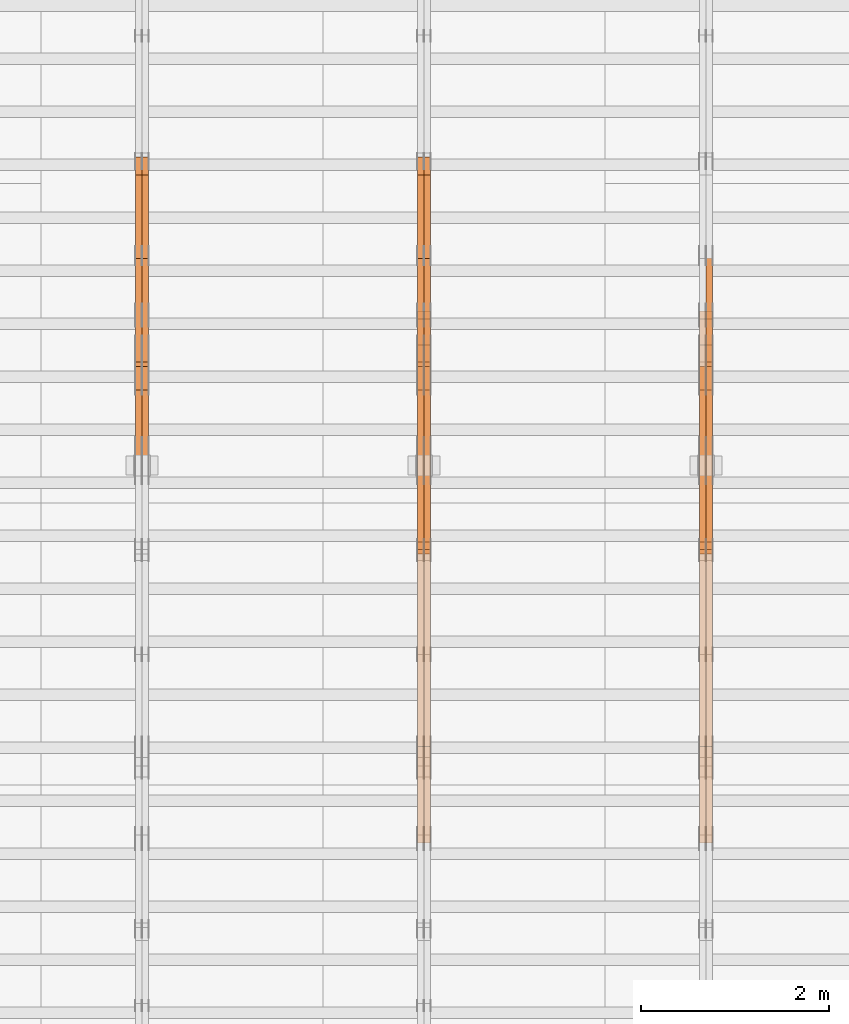
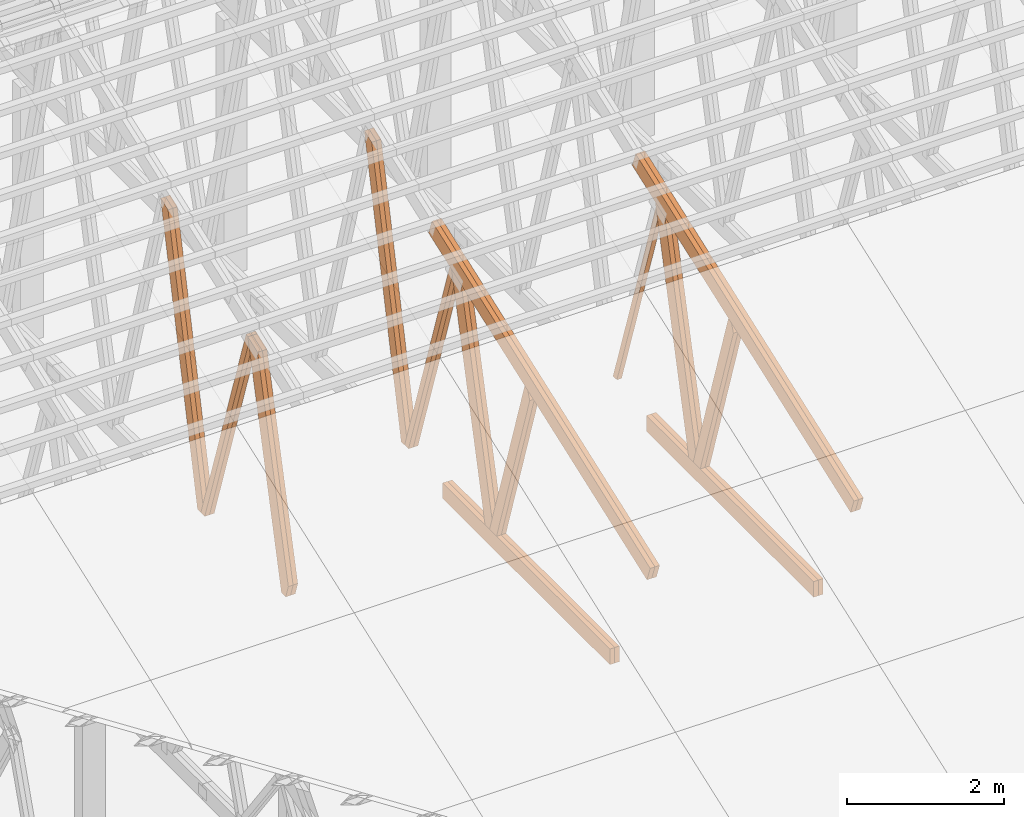
# One storey, part 25 of 189: 27 proxies.
"""IFC2X3 building model written with IfcOpenShell, lengths in millimetres."""

from ifc_helpers import new_model, entity, si_unit, converted_unit, derived_unit, direction, frame, origin, origin_2d_with_axis, place, context, subcontext, project, spatial, polyline, rectangle, outline, extrude, source, transform, mapped, material, type_object, type_shapes, element, save


model = new_model("IFC2X3")

# Units and contexts
model_context = context("Model", 3, precision=0.01, world=origin(), true_north=direction((6.12303176911189e-17, 1.0)))
body_context = subcontext(model_context, "Body", "Model", "MODEL_VIEW")
ifc_project = project(units=[si_unit("LENGTHUNIT", "METRE", prefix="MILLI"), si_unit("AREAUNIT", "SQUARE_METRE"), si_unit("VOLUMEUNIT", "CUBIC_METRE"), converted_unit("PLANEANGLEUNIT", "DEGREE", entity("IfcRatioMeasure", 0.0174532925199433), si_unit("PLANEANGLEUNIT", "RADIAN"), dimensions=[0, 0, 0, 0, 0, 0, 0]), si_unit("MASSUNIT", "GRAM", prefix="KILO"), derived_unit("MASSDENSITYUNIT", [(si_unit("MASSUNIT", "GRAM", prefix="KILO"), 1), (si_unit("LENGTHUNIT", "METRE"), -3)]), si_unit("TIMEUNIT", "SECOND"), si_unit("FREQUENCYUNIT", "HERTZ"), si_unit("THERMODYNAMICTEMPERATUREUNIT", "DEGREE_CELSIUS"), derived_unit("THERMALTRANSMITTANCEUNIT", [(si_unit("MASSUNIT", "GRAM", prefix="KILO"), 1), (si_unit("THERMODYNAMICTEMPERATUREUNIT", "KELVIN"), -1), (si_unit("TIMEUNIT", "SECOND"), -3)]), derived_unit("VOLUMETRICFLOWRATEUNIT", [(si_unit("LENGTHUNIT", "METRE"), 3), (si_unit("TIMEUNIT", "SECOND"), -1)]), si_unit("ELECTRICCURRENTUNIT", "AMPERE"), si_unit("ELECTRICVOLTAGEUNIT", "VOLT"), si_unit("POWERUNIT", "WATT"), si_unit("FORCEUNIT", "NEWTON"), si_unit("ILLUMINANCEUNIT", "LUX"), si_unit("LUMINOUSFLUXUNIT", "LUMEN"), si_unit("LUMINOUSINTENSITYUNIT", "CANDELA"), derived_unit("USERDEFINED", [(si_unit("MASSUNIT", "GRAM", prefix="KILO"), -1), (si_unit("LENGTHUNIT", "METRE"), -2), (si_unit("TIMEUNIT", "SECOND"), 3), (si_unit("LUMINOUSFLUXUNIT", "LUMEN"), 1)]), derived_unit("LINEARVELOCITYUNIT", [(si_unit("LENGTHUNIT", "METRE"), 1), (si_unit("TIMEUNIT", "SECOND"), -1)]), si_unit("PRESSUREUNIT", "PASCAL"), derived_unit("USERDEFINED", [(si_unit("LENGTHUNIT", "METRE"), -2), (si_unit("MASSUNIT", "GRAM", prefix="KILO"), 1), (si_unit("TIMEUNIT", "SECOND"), -2)])], contexts=[model_context])

# Site, building, storey
site_placement = place(None, origin())
site = spatial("IfcSite", under=ifc_project, at=site_placement, CompositionType="ELEMENT")
building_placement = place(site_placement, origin())
building = spatial("IfcBuilding", under=site, at=building_placement, CompositionType="ELEMENT")
storey_placement = place(building_placement, origin())
storey = spatial("IfcBuildingStorey", under=building, at=storey_placement, Name="Default", CompositionType="ELEMENT", Elevation=0.0)

# Proxies
ifc_material_1 = material(Name="IfcSurfaceStyle #115212")
building_element_proxy_type_1 = type_object("IfcBuildingElementProxyType", Name="T1-W7 115210", PredefinedType="NOTDEFINED", material=ifc_material_1)
shared_shape_1 = source(origin(), body_context, "Body", "SweptSolid", [
    extrude(outline(polyline([(-2158.15323194511, -47.5001976605119), (1398.58481981178, -47.5001976605119), (1473.93376219819, -0.000131511554346808), (1475.30069254941, 47.5002634162891), (-2189.66604261427, 47.5002634162891), (-2158.15323194511, -47.5001976605119)])), frame((1475.30069254941, 47.5002634162891, 0.0), z_axis=(0.0, 0.0, 1.0), x_axis=(-1.0, 0.0, 0.0)), (0.0, 0.0, 1.0), 69.9999999999998),
])
type_shapes(building_element_proxy_type_1, [shared_shape_1])
proxy_1_placement = place(building_placement, frame((21300.0, 9847.787109375, 3723.57788085937), z_axis=(-1.0, 0.0, 0.0), x_axis=(0.0, 0.314845237923105, -0.949143021971475)))
element("IfcBuildingElementProxy", 1, at=proxy_1_placement, inside=storey, type_object=building_element_proxy_type_1, material=ifc_material_1, Name="T1-W7", context=body_context, shape_type="MappedRepresentation", body=[
    mapped(shared_shape_1, transform((0.0, 0.0, 0.0), scale=1.0)),
])
ifc_material_2 = material(Name="IfcSurfaceStyle #114948")
building_element_proxy_type_2 = type_object("IfcBuildingElementProxyType", Name="T1-W1 114946", PredefinedType="NOTDEFINED", material=ifc_material_2)
shared_shape_2 = source(origin(), body_context, "Body", "SweptSolid", [
    extrude(outline(polyline([(-2144.69382208629, -109.99948311278), (1421.70798092021, -109.99948311278), (1448.88116133745, -0.000392715405943322), (1271.09900468242, 109.999679470483), (-1996.99432485378, 109.999679470483), (-2144.69382208629, -109.99948311278)])), frame((1448.88130194731, 110.000176487146, 0.0), z_axis=(0.0, 0.0, 1.0), x_axis=(-1.0, 0.0, 0.0)), (0.0, 0.0, 1.0), 69.9999999999998),
])
type_shapes(building_element_proxy_type_2, [shared_shape_2])
proxy_2_placement = place(building_placement, frame((21300.0, 8727.74270166583, 271.380182391418), z_axis=(-1.0, 0.0, 0.0), x_axis=(0.0, 0.239819839925978, 0.970817410421691)))
element("IfcBuildingElementProxy", 2, at=proxy_2_placement, inside=storey, type_object=building_element_proxy_type_2, material=ifc_material_2, Name="T1-W1", context=body_context, shape_type="MappedRepresentation", body=[
    mapped(shared_shape_2, transform((0.0, 0.0, 0.0), scale=1.0)),
])
ifc_material_3 = material(Name="IfcSurfaceStyle #114882")
building_element_proxy_type_3 = type_object("IfcBuildingElementProxyType", Name="T1-W1 114880", PredefinedType="NOTDEFINED", material=ifc_material_3)
shared_shape_3 = source(origin(), body_context, "Body", "SweptSolid", [
    extrude(outline(polyline([(-2144.69382208629, -109.99948311278), (1421.70798092021, -109.99948311278), (1448.88116133745, -0.000392715405943322), (1271.09900468242, 109.999679470483), (-1996.99432485378, 109.999679470483), (-2144.69382208629, -109.99948311278)])), frame((1448.88130194731, 110.000176487146, 0.0), z_axis=(0.0, 0.0, 1.0), x_axis=(-1.0, 0.0, 0.0)), (0.0, 0.0, 1.0), 69.9999999999998),
])
type_shapes(building_element_proxy_type_3, [shared_shape_3])
proxy_3_placement = place(building_placement, frame((21230.0, 8727.74270166583, 271.380182391418), z_axis=(-1.0, 0.0, 0.0), x_axis=(0.0, 0.239819839925978, 0.970817410421691)))
element("IfcBuildingElementProxy", 3, at=proxy_3_placement, inside=storey, type_object=building_element_proxy_type_3, material=ifc_material_3, Name="T1-W1", context=body_context, shape_type="MappedRepresentation", body=[
    mapped(shared_shape_3, transform((0.0, 0.0, 0.0), scale=1.0)),
])
ifc_material_4 = material(Name="IfcSurfaceStyle #114684")
building_element_proxy_type_4 = type_object("IfcBuildingElementProxyType", Name="T1-W4 114682", PredefinedType="NOTDEFINED", material=ifc_material_4)
shared_shape_4 = source(origin(), body_context, "Body", "SweptSolid", [
    extrude(outline(polyline([(-1688.09292256655, -85.0003489723785), (1071.44998120742, -85.0003489723785), (1178.19407811536, -0.00016040063201781), (1181.35435681367, 85.0004291726946), (-1742.9054935699, 85.0004291726946), (-1688.09292256655, -85.0003489723785)])), frame((1181.35446122976, 85.0007670757732, 0.0), z_axis=(0.0, 0.0, 1.0), x_axis=(-1.0, 0.0, 0.0)), (0.0, 0.0, 1.0), 69.9999999999998),
])
type_shapes(building_element_proxy_type_4, [shared_shape_4])
proxy_4_placement = place(building_placement, frame((21300.0, 7937.17021143291, 3028.170124945), z_axis=(-1.0, 0.0, 0.0), x_axis=(0.0, 0.306868406216492, -0.951751953644514)))
element("IfcBuildingElementProxy", 4, at=proxy_4_placement, inside=storey, type_object=building_element_proxy_type_4, material=ifc_material_4, Name="T1-W4", context=body_context, shape_type="MappedRepresentation", body=[
    mapped(shared_shape_4, transform((0.0, 0.0, 0.0), scale=1.0)),
])
ifc_material_5 = material(Name="IfcSurfaceStyle #114618")
building_element_proxy_type_5 = type_object("IfcBuildingElementProxyType", Name="T1-W4 114616", PredefinedType="NOTDEFINED", material=ifc_material_5)
shared_shape_5 = source(origin(), body_context, "Body", "SweptSolid", [
    extrude(outline(polyline([(-1688.09292256655, -85.0003489723785), (1071.44998120742, -85.0003489723785), (1178.19407811536, -0.00016040063201781), (1181.35435681367, 85.0004291726946), (-1742.9054935699, 85.0004291726946), (-1688.09292256655, -85.0003489723785)])), frame((1181.35446122976, 85.0007670757732, 0.0), z_axis=(0.0, 0.0, 1.0), x_axis=(-1.0, 0.0, 0.0)), (0.0, 0.0, 1.0), 69.9999999999998),
])
type_shapes(building_element_proxy_type_5, [shared_shape_5])
proxy_5_placement = place(building_placement, frame((21230.0, 7937.17021143291, 3028.170124945), z_axis=(-1.0, 0.0, 0.0), x_axis=(0.0, 0.306868406216492, -0.951751953644514)))
element("IfcBuildingElementProxy", 5, at=proxy_5_placement, inside=storey, type_object=building_element_proxy_type_5, material=ifc_material_5, Name="T1-W4", context=body_context, shape_type="MappedRepresentation", body=[
    mapped(shared_shape_5, transform((0.0, 0.0, 0.0), scale=1.0)),
])
ifc_material_6 = material(Name="IfcSurfaceStyle #111606")
building_element_proxy_type_6 = type_object("IfcBuildingElementProxyType", Name="T1-B6 111604", PredefinedType="NOTDEFINED", material=ifc_material_6)
shared_shape_6 = source(origin(), body_context, "Body", "SweptSolid", [
    extrude(rectangle(XDim=4266.763671875, YDim=245.000000000001, at=origin_2d_with_axis()), frame((2133.3818359375, 122.500000000001, 0.0), z_axis=(0.0, 0.0, 1.0), x_axis=(-1.0, 0.0, 0.0)), (0.0, 0.0, 1.0), 69.9999999999997),
])
type_shapes(building_element_proxy_type_6, [shared_shape_6])
proxy_6_placement = place(building_placement, frame((21300.0, 5762.466796875, 245.0), z_axis=(-1.0, 0.0, 0.0), x_axis=(0.0, 1.0, 0.0)))
element("IfcBuildingElementProxy", 6, at=proxy_6_placement, inside=storey, type_object=building_element_proxy_type_6, material=ifc_material_6, Name="T1-B6", context=body_context, shape_type="MappedRepresentation", body=[
    mapped(shared_shape_6, transform((0.0, 0.0, 0.0), scale=1.0)),
])
ifc_material_7 = material(Name="IfcSurfaceStyle #111549")
building_element_proxy_type_7 = type_object("IfcBuildingElementProxyType", Name="T1-B6 111547", PredefinedType="NOTDEFINED", material=ifc_material_7)
shared_shape_7 = source(origin(), body_context, "Body", "SweptSolid", [
    extrude(rectangle(XDim=4266.763671875, YDim=245.000000000001, at=origin_2d_with_axis()), frame((2133.3818359375, 122.500000000001, 0.0), z_axis=(0.0, 0.0, 1.0), x_axis=(-1.0, 0.0, 0.0)), (0.0, 0.0, 1.0), 69.9999999999997),
])
type_shapes(building_element_proxy_type_7, [shared_shape_7])
proxy_7_placement = place(building_placement, frame((21230.0, 5762.466796875, 245.0), z_axis=(-1.0, 0.0, 0.0), x_axis=(0.0, 1.0, 0.0)))
element("IfcBuildingElementProxy", 7, at=proxy_7_placement, inside=storey, type_object=building_element_proxy_type_7, material=ifc_material_7, Name="T1-B6", context=body_context, shape_type="MappedRepresentation", body=[
    mapped(shared_shape_7, transform((0.0, 0.0, 0.0), scale=1.0)),
])
ifc_material_8 = material(Name="IfcSurfaceStyle #111246")
building_element_proxy_type_8 = type_object("IfcBuildingElementProxyType", Name="T1-T1 111244", PredefinedType="NOTDEFINED", material=ifc_material_8)
shared_shape_8 = source(origin(), body_context, "Body", "SweptSolid", [
    extrude(outline(polyline([(-2964.99981923522, -122.500027388895), (2964.99982426074, -122.500027388895), (2964.99984011048, 122.500027388895), (-2964.99984513599, 122.500027388895), (-2964.99981923522, -122.500027388895)])), frame((2965.00021857317, 122.500056320695, 0.0), z_axis=(0.0, 0.0, 1.0), x_axis=(-1.0, 0.0, 0.0)), (0.0, 0.0, 1.0), 69.9999999999996),
])
type_shapes(building_element_proxy_type_8, [shared_shape_8])
proxy_8_placement = place(building_placement, frame((21300.0, 10391.0374749089, 3921.30478975487), z_axis=(-1.0, 0.0, 0.0), x_axis=(0.0, -0.939692620785908, -0.342020143325669)))
element("IfcBuildingElementProxy", 8, at=proxy_8_placement, inside=storey, type_object=building_element_proxy_type_8, material=ifc_material_8, Name="T1-T1", context=body_context, shape_type="MappedRepresentation", body=[
    mapped(shared_shape_8, transform((0.0, 0.0, 0.0), scale=1.0)),
])
ifc_material_9 = material(Name="IfcSurfaceStyle #111189")
building_element_proxy_type_9 = type_object("IfcBuildingElementProxyType", Name="T1-T1 111187", PredefinedType="NOTDEFINED", material=ifc_material_9)
shared_shape_9 = source(origin(), body_context, "Body", "SweptSolid", [
    extrude(outline(polyline([(-2964.99981923522, -122.500027388895), (2964.99982426074, -122.500027388895), (2964.99984011048, 122.500027388895), (-2964.99984513599, 122.500027388895), (-2964.99981923522, -122.500027388895)])), frame((2965.00021857317, 122.500056320695, 0.0), z_axis=(0.0, 0.0, 1.0), x_axis=(-1.0, 0.0, 0.0)), (0.0, 0.0, 1.0), 69.9999999999996),
])
type_shapes(building_element_proxy_type_9, [shared_shape_9])
proxy_9_placement = place(building_placement, frame((21230.0, 10391.0374749089, 3921.30478975487), z_axis=(-1.0, 0.0, 0.0), x_axis=(0.0, -0.939692620785908, -0.342020143325669)))
element("IfcBuildingElementProxy", 9, at=proxy_9_placement, inside=storey, type_object=building_element_proxy_type_9, material=ifc_material_9, Name="T1-T1", context=body_context, shape_type="MappedRepresentation", body=[
    mapped(shared_shape_9, transform((0.0, 0.0, 0.0), scale=1.0)),
])
ifc_material_10 = material(Name="IfcSurfaceStyle #99686")
building_element_proxy_type_10 = type_object("IfcBuildingElementProxyType", Name="T1-W3 99684", PredefinedType="NOTDEFINED", material=ifc_material_10)
shared_shape_10 = source(origin(), body_context, "Body", "SweptSolid", [
    extrude(outline(polyline([(-2625.55080717397, -84.9998286237256), (1749.48871563991, -84.9998286237256), (1768.20584427244, 0.000602085469291858), (1625.445846867, 85.0000405971208), (-2517.58959960538, 84.9990145648612), (-2625.55080717397, -84.9998286237256)])), frame((1768.20584427244, 85.0000405971208, 0.0), z_axis=(0.0, 0.0, 1.0), x_axis=(-1.0, 0.0, 0.0)), (0.0, 0.0, 1.0), 69.9999999999997),
])
type_shapes(building_element_proxy_type_10, [shared_shape_10])
proxy_10_placement = place(building_placement, frame((18300.0, 10918.6728403286, 263.278932236374), z_axis=(-1.0, 0.0, 0.0), x_axis=(0.0, 0.215047682154604, 0.976603550269982)))
element("IfcBuildingElementProxy", 10, at=proxy_10_placement, inside=storey, type_object=building_element_proxy_type_10, material=ifc_material_10, Name="T1-W3", context=body_context, shape_type="MappedRepresentation", body=[
    mapped(shared_shape_10, transform((0.0, 0.0, 0.0), scale=1.0)),
])
ifc_material_11 = material(Name="IfcSurfaceStyle #99620")
building_element_proxy_type_11 = type_object("IfcBuildingElementProxyType", Name="T1-W3 99618", PredefinedType="NOTDEFINED", material=ifc_material_11)
shared_shape_11 = source(origin(), body_context, "Body", "SweptSolid", [
    extrude(outline(polyline([(-2625.55080717397, -84.9998286237256), (1749.48871563991, -84.9998286237256), (1768.20584427244, 0.000602085469291858), (1625.445846867, 85.0000405971208), (-2517.58959960538, 84.9990145648612), (-2625.55080717397, -84.9998286237256)])), frame((1768.20584427244, 85.0000405971208, 0.0), z_axis=(0.0, 0.0, 1.0), x_axis=(-1.0, 0.0, 0.0)), (0.0, 0.0, 1.0), 69.9999999999997),
])
type_shapes(building_element_proxy_type_11, [shared_shape_11])
proxy_11_placement = place(building_placement, frame((18230.0, 10918.6728403286, 263.278932236374), z_axis=(-1.0, 0.0, 0.0), x_axis=(0.0, 0.215047682154604, 0.976603550269982)))
element("IfcBuildingElementProxy", 11, at=proxy_11_placement, inside=storey, type_object=building_element_proxy_type_11, material=ifc_material_11, Name="T1-W3", context=body_context, shape_type="MappedRepresentation", body=[
    mapped(shared_shape_11, transform((0.0, 0.0, 0.0), scale=1.0)),
])
ifc_material_12 = material(Name="IfcSurfaceStyle #99422")
building_element_proxy_type_12 = type_object("IfcBuildingElementProxyType", Name="T1-W7 99420", PredefinedType="NOTDEFINED", material=ifc_material_12)
shared_shape_12 = source(origin(), body_context, "Body", "SweptSolid", [
    extrude(outline(polyline([(-2158.15323194511, -47.5001976605119), (1398.58481981178, -47.5001976605119), (1473.93376219819, -0.000131511554346808), (1475.30069254941, 47.5002634162891), (-2189.66604261427, 47.5002634162891), (-2158.15323194511, -47.5001976605119)])), frame((1475.30069254941, 47.5002634162891, 0.0), z_axis=(0.0, 0.0, 1.0), x_axis=(-1.0, 0.0, 0.0)), (0.0, 0.0, 1.0), 69.9999999999998),
])
type_shapes(building_element_proxy_type_12, [shared_shape_12])
proxy_12_placement = place(building_placement, frame((18300.0, 9847.787109375, 3723.57788085937), z_axis=(-1.0, 0.0, 0.0), x_axis=(0.0, 0.314845237923105, -0.949143021971475)))
element("IfcBuildingElementProxy", 12, at=proxy_12_placement, inside=storey, type_object=building_element_proxy_type_12, material=ifc_material_12, Name="T1-W7", context=body_context, shape_type="MappedRepresentation", body=[
    mapped(shared_shape_12, transform((0.0, 0.0, 0.0), scale=1.0)),
])
ifc_material_13 = material(Name="IfcSurfaceStyle #99356")
building_element_proxy_type_13 = type_object("IfcBuildingElementProxyType", Name="T1-W7 99354", PredefinedType="NOTDEFINED", material=ifc_material_13)
shared_shape_13 = source(origin(), body_context, "Body", "SweptSolid", [
    extrude(outline(polyline([(-2158.15323194511, -47.5001976605119), (1398.58481981178, -47.5001976605119), (1473.93376219819, -0.000131511554346808), (1475.30069254941, 47.5002634162891), (-2189.66604261427, 47.5002634162891), (-2158.15323194511, -47.5001976605119)])), frame((1475.30069254941, 47.5002634162891, 0.0), z_axis=(0.0, 0.0, 1.0), x_axis=(-1.0, 0.0, 0.0)), (0.0, 0.0, 1.0), 69.9999999999998),
])
type_shapes(building_element_proxy_type_13, [shared_shape_13])
proxy_13_placement = place(building_placement, frame((18230.0, 9847.787109375, 3723.57788085937), z_axis=(-1.0, 0.0, 0.0), x_axis=(0.0, 0.314845237923105, -0.949143021971475)))
element("IfcBuildingElementProxy", 13, at=proxy_13_placement, inside=storey, type_object=building_element_proxy_type_13, material=ifc_material_13, Name="T1-W7", context=body_context, shape_type="MappedRepresentation", body=[
    mapped(shared_shape_13, transform((0.0, 0.0, 0.0), scale=1.0)),
])
ifc_material_14 = material(Name="IfcSurfaceStyle #99158")
building_element_proxy_type_14 = type_object("IfcBuildingElementProxyType", Name="T1-W1 99156", PredefinedType="NOTDEFINED", material=ifc_material_14)
shared_shape_14 = source(origin(), body_context, "Body", "SweptSolid", [
    extrude(outline(polyline([(-2144.69382208629, -109.99948311278), (1421.70798092021, -109.99948311278), (1448.88116133745, -0.000392715405943322), (1271.09900468242, 109.999679470483), (-1996.99432485378, 109.999679470483), (-2144.69382208629, -109.99948311278)])), frame((1448.88130194731, 110.000176487146, 0.0), z_axis=(0.0, 0.0, 1.0), x_axis=(-1.0, 0.0, 0.0)), (0.0, 0.0, 1.0), 69.9999999999998),
])
type_shapes(building_element_proxy_type_14, [shared_shape_14])
proxy_14_placement = place(building_placement, frame((18300.0, 8727.74270166583, 271.380182391418), z_axis=(-1.0, 0.0, 0.0), x_axis=(0.0, 0.239819839925978, 0.970817410421691)))
element("IfcBuildingElementProxy", 14, at=proxy_14_placement, inside=storey, type_object=building_element_proxy_type_14, material=ifc_material_14, Name="T1-W1", context=body_context, shape_type="MappedRepresentation", body=[
    mapped(shared_shape_14, transform((0.0, 0.0, 0.0), scale=1.0)),
])
ifc_material_15 = material(Name="IfcSurfaceStyle #99092")
building_element_proxy_type_15 = type_object("IfcBuildingElementProxyType", Name="T1-W1 99090", PredefinedType="NOTDEFINED", material=ifc_material_15)
shared_shape_15 = source(origin(), body_context, "Body", "SweptSolid", [
    extrude(outline(polyline([(-2144.69382208629, -109.99948311278), (1421.70798092021, -109.99948311278), (1448.88116133745, -0.000392715405943322), (1271.09900468242, 109.999679470483), (-1996.99432485378, 109.999679470483), (-2144.69382208629, -109.99948311278)])), frame((1448.88130194731, 110.000176487146, 0.0), z_axis=(0.0, 0.0, 1.0), x_axis=(-1.0, 0.0, 0.0)), (0.0, 0.0, 1.0), 69.9999999999998),
])
type_shapes(building_element_proxy_type_15, [shared_shape_15])
proxy_15_placement = place(building_placement, frame((18230.0, 8727.74270166583, 271.380182391418), z_axis=(-1.0, 0.0, 0.0), x_axis=(0.0, 0.239819839925978, 0.970817410421691)))
element("IfcBuildingElementProxy", 15, at=proxy_15_placement, inside=storey, type_object=building_element_proxy_type_15, material=ifc_material_15, Name="T1-W1", context=body_context, shape_type="MappedRepresentation", body=[
    mapped(shared_shape_15, transform((0.0, 0.0, 0.0), scale=1.0)),
])
ifc_material_16 = material(Name="IfcSurfaceStyle #98894")
building_element_proxy_type_16 = type_object("IfcBuildingElementProxyType", Name="T1-W4 98892", PredefinedType="NOTDEFINED", material=ifc_material_16)
shared_shape_16 = source(origin(), body_context, "Body", "SweptSolid", [
    extrude(outline(polyline([(-1688.09292256655, -85.0003489723785), (1071.44998120742, -85.0003489723785), (1178.19407811536, -0.00016040063201781), (1181.35435681367, 85.0004291726946), (-1742.9054935699, 85.0004291726946), (-1688.09292256655, -85.0003489723785)])), frame((1181.35446122976, 85.0007670757732, 0.0), z_axis=(0.0, 0.0, 1.0), x_axis=(-1.0, 0.0, 0.0)), (0.0, 0.0, 1.0), 69.9999999999998),
])
type_shapes(building_element_proxy_type_16, [shared_shape_16])
proxy_16_placement = place(building_placement, frame((18300.0, 7937.17021143291, 3028.170124945), z_axis=(-1.0, 0.0, 0.0), x_axis=(0.0, 0.306868406216492, -0.951751953644514)))
element("IfcBuildingElementProxy", 16, at=proxy_16_placement, inside=storey, type_object=building_element_proxy_type_16, material=ifc_material_16, Name="T1-W4", context=body_context, shape_type="MappedRepresentation", body=[
    mapped(shared_shape_16, transform((0.0, 0.0, 0.0), scale=1.0)),
])
ifc_material_17 = material(Name="IfcSurfaceStyle #98828")
building_element_proxy_type_17 = type_object("IfcBuildingElementProxyType", Name="T1-W4 98826", PredefinedType="NOTDEFINED", material=ifc_material_17)
shared_shape_17 = source(origin(), body_context, "Body", "SweptSolid", [
    extrude(outline(polyline([(-1688.09292256655, -85.0003489723785), (1071.44998120742, -85.0003489723785), (1178.19407811536, -0.00016040063201781), (1181.35435681367, 85.0004291726946), (-1742.9054935699, 85.0004291726946), (-1688.09292256655, -85.0003489723785)])), frame((1181.35446122976, 85.0007670757732, 0.0), z_axis=(0.0, 0.0, 1.0), x_axis=(-1.0, 0.0, 0.0)), (0.0, 0.0, 1.0), 69.9999999999998),
])
type_shapes(building_element_proxy_type_17, [shared_shape_17])
proxy_17_placement = place(building_placement, frame((18230.0, 7937.17021143291, 3028.170124945), z_axis=(-1.0, 0.0, 0.0), x_axis=(0.0, 0.306868406216492, -0.951751953644514)))
element("IfcBuildingElementProxy", 17, at=proxy_17_placement, inside=storey, type_object=building_element_proxy_type_17, material=ifc_material_17, Name="T1-W4", context=body_context, shape_type="MappedRepresentation", body=[
    mapped(shared_shape_17, transform((0.0, 0.0, 0.0), scale=1.0)),
])
ifc_material_18 = material(Name="IfcSurfaceStyle #95816")
building_element_proxy_type_18 = type_object("IfcBuildingElementProxyType", Name="T1-B6 95814", PredefinedType="NOTDEFINED", material=ifc_material_18)
shared_shape_18 = source(origin(), body_context, "Body", "SweptSolid", [
    extrude(rectangle(XDim=4266.763671875, YDim=245.000000000001, at=origin_2d_with_axis()), frame((2133.3818359375, 122.500000000001, 0.0), z_axis=(0.0, 0.0, 1.0), x_axis=(-1.0, 0.0, 0.0)), (0.0, 0.0, 1.0), 69.9999999999997),
])
type_shapes(building_element_proxy_type_18, [shared_shape_18])
proxy_18_placement = place(building_placement, frame((18300.0, 5762.466796875, 245.0), z_axis=(-1.0, 0.0, 0.0), x_axis=(0.0, 1.0, 0.0)))
element("IfcBuildingElementProxy", 18, at=proxy_18_placement, inside=storey, type_object=building_element_proxy_type_18, material=ifc_material_18, Name="T1-B6", context=body_context, shape_type="MappedRepresentation", body=[
    mapped(shared_shape_18, transform((0.0, 0.0, 0.0), scale=1.0)),
])
ifc_material_19 = material(Name="IfcSurfaceStyle #95759")
building_element_proxy_type_19 = type_object("IfcBuildingElementProxyType", Name="T1-B6 95757", PredefinedType="NOTDEFINED", material=ifc_material_19)
shared_shape_19 = source(origin(), body_context, "Body", "SweptSolid", [
    extrude(rectangle(XDim=4266.763671875, YDim=245.000000000001, at=origin_2d_with_axis()), frame((2133.3818359375, 122.500000000001, 0.0), z_axis=(0.0, 0.0, 1.0), x_axis=(-1.0, 0.0, 0.0)), (0.0, 0.0, 1.0), 69.9999999999997),
])
type_shapes(building_element_proxy_type_19, [shared_shape_19])
proxy_19_placement = place(building_placement, frame((18230.0, 5762.466796875, 245.0), z_axis=(-1.0, 0.0, 0.0), x_axis=(0.0, 1.0, 0.0)))
element("IfcBuildingElementProxy", 19, at=proxy_19_placement, inside=storey, type_object=building_element_proxy_type_19, material=ifc_material_19, Name="T1-B6", context=body_context, shape_type="MappedRepresentation", body=[
    mapped(shared_shape_19, transform((0.0, 0.0, 0.0), scale=1.0)),
])
ifc_material_20 = material(Name="IfcSurfaceStyle #95456")
building_element_proxy_type_20 = type_object("IfcBuildingElementProxyType", Name="T1-T1 95454", PredefinedType="NOTDEFINED", material=ifc_material_20)
shared_shape_20 = source(origin(), body_context, "Body", "SweptSolid", [
    extrude(outline(polyline([(-2964.99981923522, -122.500027388895), (2964.99982426074, -122.500027388895), (2964.99984011048, 122.500027388895), (-2964.99984513599, 122.500027388895), (-2964.99981923522, -122.500027388895)])), frame((2965.00021857317, 122.500056320695, 0.0), z_axis=(0.0, 0.0, 1.0), x_axis=(-1.0, 0.0, 0.0)), (0.0, 0.0, 1.0), 69.9999999999996),
])
type_shapes(building_element_proxy_type_20, [shared_shape_20])
proxy_20_placement = place(building_placement, frame((18300.0, 10391.0374749089, 3921.30478975487), z_axis=(-1.0, 0.0, 0.0), x_axis=(0.0, -0.939692620785908, -0.342020143325669)))
element("IfcBuildingElementProxy", 20, at=proxy_20_placement, inside=storey, type_object=building_element_proxy_type_20, material=ifc_material_20, Name="T1-T1", context=body_context, shape_type="MappedRepresentation", body=[
    mapped(shared_shape_20, transform((0.0, 0.0, 0.0), scale=1.0)),
])
ifc_material_21 = material(Name="IfcSurfaceStyle #95399")
building_element_proxy_type_21 = type_object("IfcBuildingElementProxyType", Name="T1-T1 95397", PredefinedType="NOTDEFINED", material=ifc_material_21)
shared_shape_21 = source(origin(), body_context, "Body", "SweptSolid", [
    extrude(outline(polyline([(-2964.99981923522, -122.500027388895), (2964.99982426074, -122.500027388895), (2964.99984011048, 122.500027388895), (-2964.99984513599, 122.500027388895), (-2964.99981923522, -122.500027388895)])), frame((2965.00021857317, 122.500056320695, 0.0), z_axis=(0.0, 0.0, 1.0), x_axis=(-1.0, 0.0, 0.0)), (0.0, 0.0, 1.0), 69.9999999999996),
])
type_shapes(building_element_proxy_type_21, [shared_shape_21])
proxy_21_placement = place(building_placement, frame((18230.0, 10391.0374749089, 3921.30478975487), z_axis=(-1.0, 0.0, 0.0), x_axis=(0.0, -0.939692620785908, -0.342020143325669)))
element("IfcBuildingElementProxy", 21, at=proxy_21_placement, inside=storey, type_object=building_element_proxy_type_21, material=ifc_material_21, Name="T1-T1", context=body_context, shape_type="MappedRepresentation", body=[
    mapped(shared_shape_21, transform((0.0, 0.0, 0.0), scale=1.0)),
])
ifc_material_22 = material(Name="IfcSurfaceStyle #83896")
building_element_proxy_type_22 = type_object("IfcBuildingElementProxyType", Name="T1-W3 83894", PredefinedType="NOTDEFINED", material=ifc_material_22)
shared_shape_22 = source(origin(), body_context, "Body", "SweptSolid", [
    extrude(outline(polyline([(-2625.55080717397, -84.9998286237256), (1749.48871563991, -84.9998286237256), (1768.20584427244, 0.000602085469291858), (1625.445846867, 85.0000405971208), (-2517.58959960538, 84.9990145648612), (-2625.55080717397, -84.9998286237256)])), frame((1768.20584427244, 85.0000405971208, 0.0), z_axis=(0.0, 0.0, 1.0), x_axis=(-1.0, 0.0, 0.0)), (0.0, 0.0, 1.0), 69.9999999999997),
])
type_shapes(building_element_proxy_type_22, [shared_shape_22])
proxy_22_placement = place(building_placement, frame((15300.0, 10918.6728403286, 263.278932236374), z_axis=(-1.0, 0.0, 0.0), x_axis=(0.0, 0.215047682154604, 0.976603550269982)))
element("IfcBuildingElementProxy", 22, at=proxy_22_placement, inside=storey, type_object=building_element_proxy_type_22, material=ifc_material_22, Name="T1-W3", context=body_context, shape_type="MappedRepresentation", body=[
    mapped(shared_shape_22, transform((0.0, 0.0, 0.0), scale=1.0)),
])
ifc_material_23 = material(Name="IfcSurfaceStyle #83830")
building_element_proxy_type_23 = type_object("IfcBuildingElementProxyType", Name="T1-W3 83828", PredefinedType="NOTDEFINED", material=ifc_material_23)
shared_shape_23 = source(origin(), body_context, "Body", "SweptSolid", [
    extrude(outline(polyline([(-2625.55080717397, -84.9998286237256), (1749.48871563991, -84.9998286237256), (1768.20584427244, 0.000602085469291858), (1625.445846867, 85.0000405971208), (-2517.58959960538, 84.9990145648612), (-2625.55080717397, -84.9998286237256)])), frame((1768.20584427244, 85.0000405971208, 0.0), z_axis=(0.0, 0.0, 1.0), x_axis=(-1.0, 0.0, 0.0)), (0.0, 0.0, 1.0), 69.9999999999997),
])
type_shapes(building_element_proxy_type_23, [shared_shape_23])
proxy_23_placement = place(building_placement, frame((15230.0, 10918.6728403286, 263.278932236374), z_axis=(-1.0, 0.0, 0.0), x_axis=(0.0, 0.215047682154604, 0.976603550269982)))
element("IfcBuildingElementProxy", 23, at=proxy_23_placement, inside=storey, type_object=building_element_proxy_type_23, material=ifc_material_23, Name="T1-W3", context=body_context, shape_type="MappedRepresentation", body=[
    mapped(shared_shape_23, transform((0.0, 0.0, 0.0), scale=1.0)),
])
ifc_material_24 = material(Name="IfcSurfaceStyle #83632")
building_element_proxy_type_24 = type_object("IfcBuildingElementProxyType", Name="T1-W7 83630", PredefinedType="NOTDEFINED", material=ifc_material_24)
shared_shape_24 = source(origin(), body_context, "Body", "SweptSolid", [
    extrude(outline(polyline([(-2158.15323194511, -47.5001976605119), (1398.58481981178, -47.5001976605119), (1473.93376219819, -0.000131511554346808), (1475.30069254941, 47.5002634162891), (-2189.66604261427, 47.5002634162891), (-2158.15323194511, -47.5001976605119)])), frame((1475.30069254941, 47.5002634162891, 0.0), z_axis=(0.0, 0.0, 1.0), x_axis=(-1.0, 0.0, 0.0)), (0.0, 0.0, 1.0), 69.9999999999998),
])
type_shapes(building_element_proxy_type_24, [shared_shape_24])
proxy_24_placement = place(building_placement, frame((15300.0, 9847.787109375, 3723.57788085937), z_axis=(-1.0, 0.0, 0.0), x_axis=(0.0, 0.314845237923105, -0.949143021971475)))
element("IfcBuildingElementProxy", 24, at=proxy_24_placement, inside=storey, type_object=building_element_proxy_type_24, material=ifc_material_24, Name="T1-W7", context=body_context, shape_type="MappedRepresentation", body=[
    mapped(shared_shape_24, transform((0.0, 0.0, 0.0), scale=1.0)),
])
ifc_material_25 = material(Name="IfcSurfaceStyle #83566")
building_element_proxy_type_25 = type_object("IfcBuildingElementProxyType", Name="T1-W7 83564", PredefinedType="NOTDEFINED", material=ifc_material_25)
shared_shape_25 = source(origin(), body_context, "Body", "SweptSolid", [
    extrude(outline(polyline([(-2158.15323194511, -47.5001976605119), (1398.58481981178, -47.5001976605119), (1473.93376219819, -0.000131511554346808), (1475.30069254941, 47.5002634162891), (-2189.66604261427, 47.5002634162891), (-2158.15323194511, -47.5001976605119)])), frame((1475.30069254941, 47.5002634162891, 0.0), z_axis=(0.0, 0.0, 1.0), x_axis=(-1.0, 0.0, 0.0)), (0.0, 0.0, 1.0), 69.9999999999998),
])
type_shapes(building_element_proxy_type_25, [shared_shape_25])
proxy_25_placement = place(building_placement, frame((15230.0, 9847.787109375, 3723.57788085937), z_axis=(-1.0, 0.0, 0.0), x_axis=(0.0, 0.314845237923105, -0.949143021971475)))
element("IfcBuildingElementProxy", 25, at=proxy_25_placement, inside=storey, type_object=building_element_proxy_type_25, material=ifc_material_25, Name="T1-W7", context=body_context, shape_type="MappedRepresentation", body=[
    mapped(shared_shape_25, transform((0.0, 0.0, 0.0), scale=1.0)),
])
ifc_material_26 = material(Name="IfcSurfaceStyle #83368")
building_element_proxy_type_26 = type_object("IfcBuildingElementProxyType", Name="T1-W1 83366", PredefinedType="NOTDEFINED", material=ifc_material_26)
shared_shape_26 = source(origin(), body_context, "Body", "SweptSolid", [
    extrude(outline(polyline([(-2144.69382208629, -109.99948311278), (1421.70798092021, -109.99948311278), (1448.88116133745, -0.000392715405943322), (1271.09900468242, 109.999679470483), (-1996.99432485378, 109.999679470483), (-2144.69382208629, -109.99948311278)])), frame((1448.88130194731, 110.000176487146, 0.0), z_axis=(0.0, 0.0, 1.0), x_axis=(-1.0, 0.0, 0.0)), (0.0, 0.0, 1.0), 69.9999999999998),
])
type_shapes(building_element_proxy_type_26, [shared_shape_26])
proxy_26_placement = place(building_placement, frame((15300.0, 8727.74270166583, 271.380182391418), z_axis=(-1.0, 0.0, 0.0), x_axis=(0.0, 0.239819839925978, 0.970817410421691)))
element("IfcBuildingElementProxy", 26, at=proxy_26_placement, inside=storey, type_object=building_element_proxy_type_26, material=ifc_material_26, Name="T1-W1", context=body_context, shape_type="MappedRepresentation", body=[
    mapped(shared_shape_26, transform((0.0, 0.0, 0.0), scale=1.0)),
])
ifc_material_27 = material(Name="IfcSurfaceStyle #83302")
building_element_proxy_type_27 = type_object("IfcBuildingElementProxyType", Name="T1-W1 83300", PredefinedType="NOTDEFINED", material=ifc_material_27)
shared_shape_27 = source(origin(), body_context, "Body", "SweptSolid", [
    extrude(outline(polyline([(-2144.69382208629, -109.99948311278), (1421.70798092021, -109.99948311278), (1448.88116133745, -0.000392715405943322), (1271.09900468242, 109.999679470483), (-1996.99432485378, 109.999679470483), (-2144.69382208629, -109.99948311278)])), frame((1448.88130194731, 110.000176487146, 0.0), z_axis=(0.0, 0.0, 1.0), x_axis=(-1.0, 0.0, 0.0)), (0.0, 0.0, 1.0), 69.9999999999998),
])
type_shapes(building_element_proxy_type_27, [shared_shape_27])
proxy_27_placement = place(building_placement, frame((15230.0, 8727.74270166583, 271.380182391418), z_axis=(-1.0, 0.0, 0.0), x_axis=(0.0, 0.239819839925978, 0.970817410421691)))
element("IfcBuildingElementProxy", 27, at=proxy_27_placement, inside=storey, type_object=building_element_proxy_type_27, material=ifc_material_27, Name="T1-W1", context=body_context, shape_type="MappedRepresentation", body=[
    mapped(shared_shape_27, transform((0.0, 0.0, 0.0), scale=1.0)),
])

save(model, "model.ifc")
